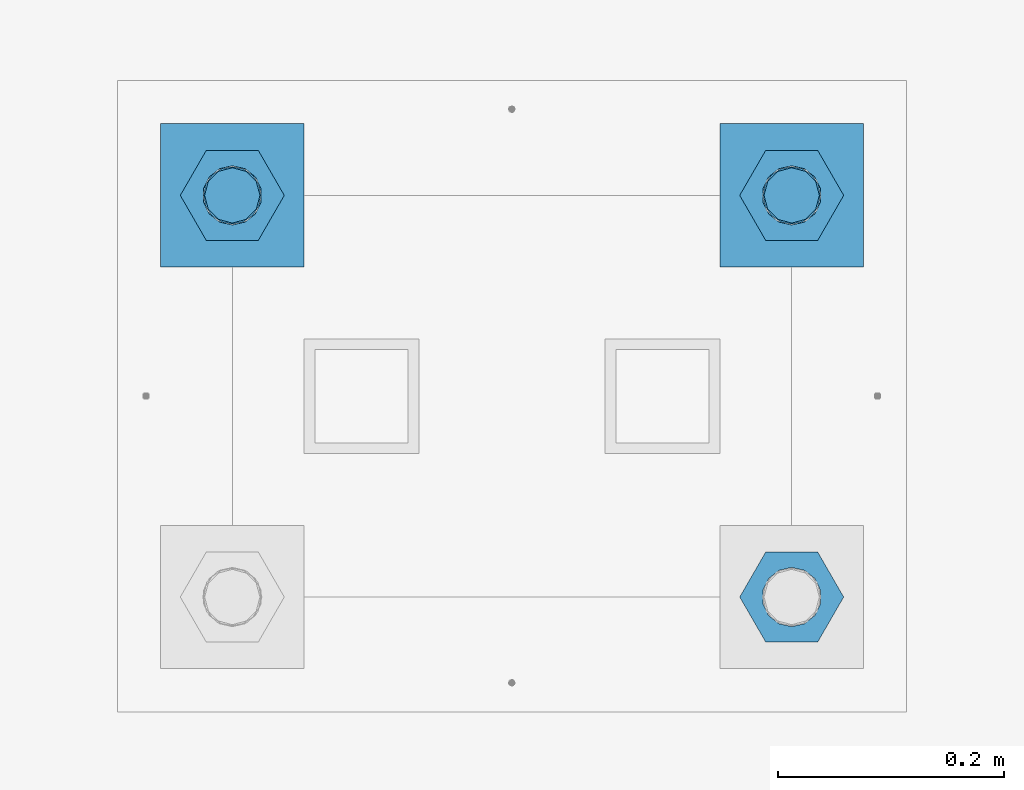
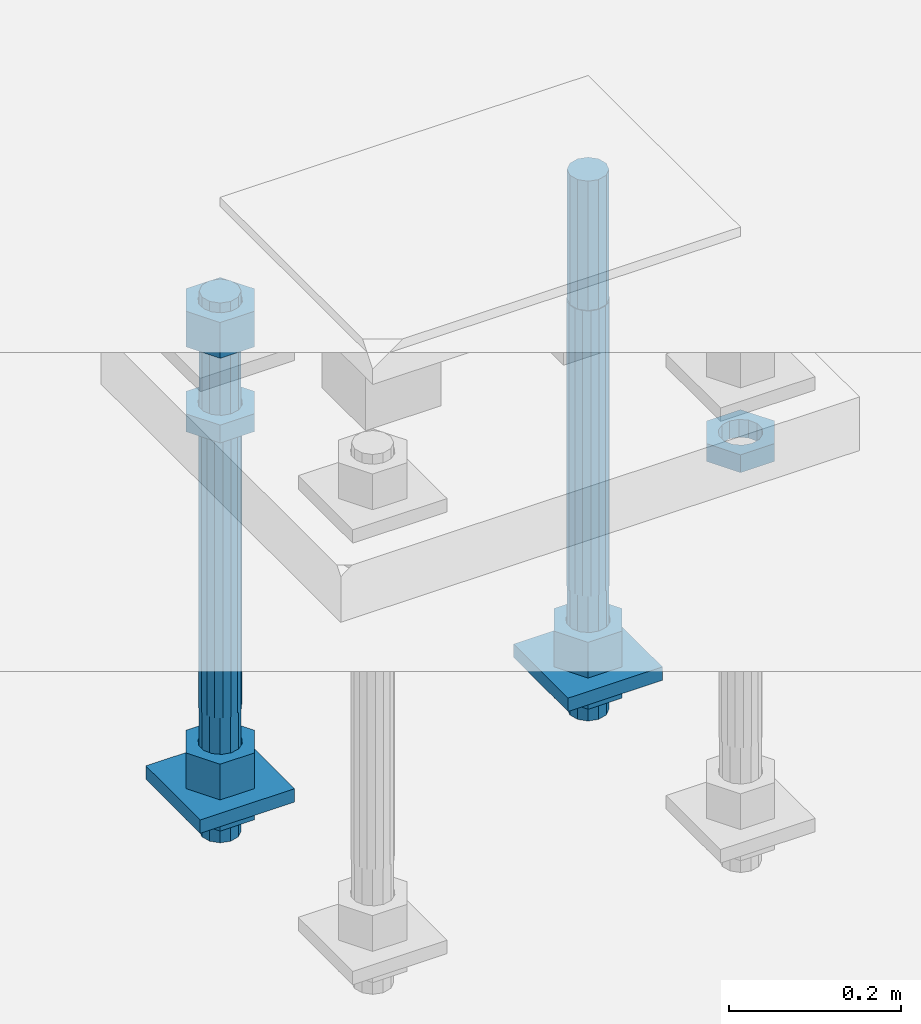
# One storey, part 2691 of 3843: 11 beams, 1 element without a shape of its own.
"""IFC2X3 building model written with IfcOpenShell, lengths in millimetres."""

import ifcopenshell
import ifcopenshell.guid

model = None  # the IFC model being written
_history = None  # IfcOwnerHistory: only IFC2X3 demands one
_inside = {}  # id of a spatial element -> (the spatial element, [elements in it])
_under = {}  # id of a project, library or spatial element -> (it, [spatial elements below it])
_declared = {}  # id of a project -> (the project, [libraries it declares])
_typed = {}  # id of a type object -> (the type object, [elements of that type])
_made_of = {}  # id of a material, layer set ... -> (it, [elements and type objects made of it])


def new_model(schema):
    """Start an empty IFC model of exactly this schema.

    Asked for "IFC4X3", IfcOpenShell would pick the latest addendum, in which some entities
    have other attributes; the version numbers below select the first issue.
    IFC2X3 requires an IfcOwnerHistory on every rooted entity: one is made here for all.
    """
    global model, _history
    if schema == "IFC4X3":
        model = ifcopenshell.file(schema_version=(4, 3, 0, 0))
    else:
        model = ifcopenshell.file(schema=schema)
    _inside.clear()
    _under.clear()
    _declared.clear()
    _typed.clear()
    _made_of.clear()
    _history = None
    if model.schema == "IFC2X3":
        org = make("IfcOrganization", Name="unknown")
        user = make(
            "IfcPersonAndOrganization",
            ThePerson=make("IfcPerson", FamilyName="unknown"),
            TheOrganization=org,
        )
        app = make(
            "IfcApplication",
            ApplicationDeveloper=org,
            Version="unknown",
            ApplicationFullName="unknown",
            ApplicationIdentifier="unknown",
        )
        _history = make(
            "IfcOwnerHistory",
            OwningUser=user,
            OwningApplication=app,
            ChangeAction="ADDED",
            CreationDate=0,
        )
    return model


def make(cls, **values):
    """One entity of the class cls with the attributes given. An attribute that is None is left unset."""
    return model.create_entity(
        cls, **{name: value for name, value in values.items() if value is not None}
    )


def rooted(cls, **values):
    """An entity with a GlobalId (a new one), such as an element, a storey or a relation."""
    return make(cls, GlobalId=ifcopenshell.guid.new(), OwnerHistory=_history, **values)


def si_unit(unit_type, name, prefix=None):
    """IfcSIUnit, for example si_unit("LENGTHUNIT", "METRE", prefix="MILLI")."""
    return make("IfcSIUnit", UnitType=unit_type, Prefix=prefix, Name=name)


def assignment(units):
    """IfcUnitAssignment: the units of a project."""
    return None if units is None else make("IfcUnitAssignment", Units=units)


def point(xyz):
    """IfcCartesianPoint."""
    return None if xyz is None else make("IfcCartesianPoint", Coordinates=xyz)


def direction(xyz):
    """IfcDirection."""
    return None if xyz is None else make("IfcDirection", DirectionRatios=xyz)


def frame(location, z_axis=None, x_axis=None):
    """IfcAxis2Placement3D, a coordinate frame: its origin and axes. An axis left out is left unset."""
    return make(
        "IfcAxis2Placement3D",
        Location=point(location),
        Axis=direction(z_axis),
        RefDirection=direction(x_axis),
    )


def origin_with_axes():
    """The frame at (0, 0, 0) with the z axis (0, 0, 1) and the x axis (1, 0, 0) written out."""
    return frame((0.0, 0.0, 0.0), z_axis=(0.0, 0.0, 1.0), x_axis=(1.0, 0.0, 0.0))


def place(relative_to, where):
    """IfcLocalPlacement: puts the frame where relative to a parent placement (None: the world)."""
    return make(
        "IfcLocalPlacement", PlacementRelTo=relative_to, RelativePlacement=where
    )


def context(
    kind, dimensions, precision=None, world=None, true_north=None, identifier=None
):
    """IfcGeometricRepresentationContext, for example the 3D "Model" context."""
    return make(
        "IfcGeometricRepresentationContext",
        ContextIdentifier=identifier,
        ContextType=kind,
        CoordinateSpaceDimension=dimensions,
        Precision=precision,
        WorldCoordinateSystem=world,
        TrueNorth=true_north,
    )


def subcontext(parent, identifier, kind, view, scale=None):
    """IfcGeometricRepresentationSubContext, for example "Body" below "Model"."""
    return make(
        "IfcGeometricRepresentationSubContext",
        ContextIdentifier=identifier,
        ContextType=kind,
        ParentContext=parent,
        TargetScale=scale,
        TargetView=view,
    )


def project(units=None, contexts=None):
    """IfcProject with its units and contexts."""
    return rooted(
        "IfcProject",
        Name="project",
        RepresentationContexts=contexts,
        UnitsInContext=assignment(units),
    )


def spatial(cls, under=None, at=None, **own):
    """A site, building, storey or space (cls), placed at a placement, below another one or the project."""
    s = rooted(cls, ObjectPlacement=at, **own)
    if under is not None:
        _under.setdefault(under.id(), (under, []))[1].append(s)
    return s


def faces_of(points, faces, orient=None, outer=None):
    """IfcFace entities. A face is a list of loops; a loop is a list of indices into points, from 0.

    orient and outer hold one flag for each loop. By default every Orientation is true, the
    first loop of a face is its IfcFaceOuterBound and the others are IfcFaceBound.
    """
    made = []
    for i, loops in enumerate(faces):
        bounds = []
        for j, loop in enumerate(loops):
            is_outer = j == 0 if outer is None else outer[i][j]
            bounds.append(
                make(
                    "IfcFaceOuterBound" if is_outer else "IfcFaceBound",
                    Bound=make("IfcPolyLoop", Polygon=[points[k] for k in loop]),
                    Orientation=True if orient is None else orient[i][j],
                )
            )
        made.append(make("IfcFace", Bounds=bounds))
    return made


def faceted_brep(points, faces, orient=None, outer=None, voids=None):
    """IfcFacetedBrep: a solid bounded by flat faces; with voids (closed shells), ...WithVoids."""
    shared = [point(p) for p in points]
    hull = make("IfcClosedShell", CfsFaces=faces_of(shared, faces, orient, outer))
    if voids is None:
        return make("IfcFacetedBrep", Outer=hull)
    return make(
        "IfcFacetedBrepWithVoids",
        Outer=hull,
        Voids=[
            make(cls, CfsFaces=faces_of(shared, fs, o, b)) for cls, fs, o, b in voids
        ],
    )


def shape(context_of_items, identifier, shape_type, items):
    """IfcShapeRepresentation: the items that make up one representation, for example the "Body"."""
    return make(
        "IfcShapeRepresentation",
        ContextOfItems=context_of_items,
        RepresentationIdentifier=identifier,
        RepresentationType=shape_type,
        Items=items,
    )


def material(Name=None, Category=None):
    """IfcMaterial."""
    return make("IfcMaterial", Name=Name, Category=Category)


def made_of(thing, what):
    """Note that an element or type object is made of a material, layer set ...; save() writes the relation."""
    if what is not None:
        _made_of.setdefault(what.id(), (what, []))[1].append(thing)
    return thing


def type_object(cls, material=None, **own):
    """A type object (cls), such as IfcWallType, which elements share."""
    return made_of(rooted(cls, **own), material)


def element(
    cls,
    number,
    at=None,
    inside=None,
    cuts=None,
    type_object=None,
    material=None,
    context=None,
    identifier="Body",
    shape_type=None,
    held_by="IfcProductDefinitionShape",
    body=None,
    shapes=None,
    **own,
):
    """One element of the class cls, such as IfcWall. Its Tag is "e" and its number.

    at: its placement. inside: the storey or other place that contains it. cuts: it is an
    opening in that element (IfcRelVoidsElement). A single representation is given by context,
    identifier, shape_type and body (its items); several are given by shapes. held_by: the class
    of the entity that holds the representations. save() writes the other relations.
    """
    e = rooted(cls, Tag="e%d" % number, ObjectPlacement=at, **own)
    if body is not None:
        shapes = [shape(context, identifier, shape_type, body)]
    if shapes is not None:
        e.Representation = make(held_by, Representations=shapes)
    if inside is not None:
        _inside.setdefault(inside.id(), (inside, []))[1].append(e)
    if cuts is not None:
        rooted(
            "IfcRelVoidsElement", RelatingBuildingElement=cuts, RelatedOpeningElement=e
        )
    if type_object is not None:
        _typed.setdefault(type_object.id(), (type_object, []))[1].append(e)
    return made_of(e, material)


def aggregate(whole, parts):
    """IfcRelAggregates: a whole, such as a stair, and the parts it consists of."""
    return rooted("IfcRelAggregates", RelatingObject=whole, RelatedObjects=parts)


def save(model, path):
    """Write the relations noted so far, then the file.

    IfcRelAggregates (storeys below a building ...), IfcRelContainedInSpatialStructure (elements
    in a storey), IfcRelDefinesByType, IfcRelAssociatesMaterial and IfcRelDeclares: one each for
    every whole, place, type object, material and project.
    """
    for whole, parts in _under.values():
        aggregate(whole, parts)
    for where, things in _inside.values():
        rooted(
            "IfcRelContainedInSpatialStructure",
            RelatedElements=things,
            RelatingStructure=where,
        )
    for kind, things in _typed.values():
        rooted("IfcRelDefinesByType", RelatedObjects=things, RelatingType=kind)
    for what, things in _made_of.values():
        rooted("IfcRelAssociatesMaterial", RelatedObjects=things, RelatingMaterial=what)
    for by, libraries in _declared.values():
        rooted("IfcRelDeclares", RelatingContext=by, RelatedDefinitions=libraries)
    model.write(path)


model = new_model("IFC2X3")

# Units and contexts
model_context = context("Model", 3, precision=1e-05, world=origin_with_axes())
body_context = subcontext(model_context, "Body", "Model", "MODEL_VIEW")
ifc_project = project(units=[si_unit("LENGTHUNIT", "METRE", prefix="MILLI"), si_unit("AREAUNIT", "SQUARE_METRE"), si_unit("VOLUMEUNIT", "CUBIC_METRE"), si_unit("MASSUNIT", "GRAM", prefix="KILO"), si_unit("TIMEUNIT", "SECOND"), si_unit("PLANEANGLEUNIT", "RADIAN"), si_unit("SOLIDANGLEUNIT", "STERADIAN"), si_unit("THERMODYNAMICTEMPERATUREUNIT", "DEGREE_CELSIUS"), si_unit("LUMINOUSINTENSITYUNIT", "LUMEN")], contexts=[model_context])

# Site, building, storey
site_placement = place(None, origin_with_axes())
site = spatial("IfcSite", under=ifc_project, at=site_placement, CompositionType="ELEMENT")
building_placement = place(site_placement, origin_with_axes())
building = spatial("IfcBuilding", under=site, at=building_placement, Name="Undefined", CompositionType="ELEMENT")
storey_placement = place(building_placement, origin_with_axes())
storey = spatial("IfcBuildingStorey", under=building, at=storey_placement, Name="Undefined", CompositionType="ELEMENT", Elevation=0.0)

# Assembly, beams
assembly_placement = place(storey_placement, origin_with_axes())
assembly = element("IfcElementAssembly", 1, at=assembly_placement, inside=storey, Name="TEMPLATE", AssemblyPlace="NOTDEFINED", PredefinedType="RIGID_FRAME")
ifc_material_1 = material(Name="STEEL/A572-50")
beam_type_1 = type_object("IfcBeamType", PredefinedType="NOTDEFINED")
beam_1_placement = place(assembly_placement, frame((105403.65, 36258.4999984741, 29244.925), z_axis=(-1.0, 0.0, 0.0), x_axis=(0.0, -1.0, 0.0)))
beam_1 = element("IfcBeam", 2, at=beam_1_placement, type_object=beam_type_1, material=ifc_material_1, Name="WASHER_PLATE", context=body_context, shape_type="Brep", body=[
    faceted_brep([(0.0, 9.52500000000146, -63.5), (0.0, 9.52500000000146, 63.5), (127.0, 9.52500000000146, 63.5), (127.0, 9.52500000000146, -63.5), (0.0, -9.52500000000146, 63.5), (127.0, -9.52500000000146, 63.5), (0.0, -9.52500000000146, -63.5), (127.0, -9.52500000000146, -63.5)], [[[0, 1, 2, 3]], [[1, 4, 5, 2]], [[4, 6, 7, 5]], [[6, 0, 3, 7]], [[5, 7, 3, 2]], [[6, 4, 1, 0]]]),
])
beam_2_placement = place(assembly_placement, frame((104908.35, 36258.4999984741, 29244.925), z_axis=(-1.0, 0.0, 0.0), x_axis=(0.0, -1.0, 0.0)))
beam_2 = element("IfcBeam", 3, at=beam_2_placement, type_object=beam_type_1, material=ifc_material_1, Name="WASHER_PLATE", context=body_context, shape_type="Brep", body=[
    faceted_brep([(0.0, 9.52500000000146, -63.5), (0.0, 9.52500000000146, 63.5), (127.0, 9.52500000000146, 63.5), (127.0, 9.52500000000146, -63.5), (0.0, -9.52500000000146, 63.5), (127.0, -9.52500000000146, 63.5), (0.0, -9.52500000000146, -63.5), (127.0, -9.52500000000146, -63.5)], [[[0, 1, 2, 3]], [[1, 4, 5, 2]], [[4, 6, 7, 5]], [[6, 0, 3, 7]], [[5, 7, 3, 2]], [[6, 4, 1, 0]]]),
])
ifc_material_2 = material(Name="STEEL/A36")
beam_type_2 = type_object("IfcBeamType", Name="2_HALF_NUT", PredefinedType="NOTDEFINED")
beam_3_placement = place(assembly_placement, frame((105403.65, 36194.9999984741, 29235.4), z_axis=(0.0, -1.0, 0.0), x_axis=(0.0, 0.0, -1.0)))
beam_3 = element("IfcBeam", 4, at=beam_3_placement, type_object=beam_type_2, material=ifc_material_2, Name="NUT", ObjectType="2_HALF_NUT", context=body_context, shape_type="Brep", body=[
    faceted_brep([(0.0, -46.0369987487793, 0.0), (0.0, -23.0184993743896, -39.869213104248), (25.4000000000015, -23.0184993743896, -39.869213104248), (25.4000000000015, -46.0369987487793, 0.0), (0.0, 23.0184993743896, -39.869213104248), (25.4000000000015, 23.0184993743896, -39.869213104248), (0.0, 46.0369987487793, 0.0), (25.4000000000015, 46.0369987487793, 0.0), (0.0, 23.0184993743896, 39.869213104248), (25.4000000000015, 23.0184993743896, 39.869213104248), (0.0, -23.0184993743896, 39.869213104248), (25.4000000000015, -23.0184993743896, 39.869213104248), (0.0, 0.0, 26.1940002441406), (0.0, 11.3650617044477, 23.5999013092805), (25.4000000000015, 11.3650617044477, 23.5999013092805), (25.4000000000015, 0.0, 26.1940002441406), (0.0, 20.4791109456419, 16.3316083006721), (25.4000000000015, 20.4791109456419, 16.3316083006721), (0.0, 25.5370200498292, 5.82867859874386), (25.4000000000015, 25.5370200498292, 5.82867859874386), (0.0, 25.5370200498292, -5.82867859874386), (25.4000000000015, 25.5370200498292, -5.82867859874386), (0.0, 20.4791109456419, -16.3316083006721), (25.4000000000015, 20.4791109456419, -16.3316083006721), (0.0, 11.3650617044477, -23.5999013092805), (25.4000000000015, 11.3650617044477, -23.5999013092805), (0.0, 0.0, -26.1940002441406), (25.4000000000015, 0.0, -26.1940002441406), (0.0, -11.3650617044477, -23.5999013092805), (25.4000000000015, -11.3650617044477, -23.5999013092805), (0.0, -20.4791109456419, -16.3316083006721), (25.4000000000015, -20.4791109456419, -16.3316083006721), (0.0, -25.5370200498292, -5.82867859874386), (25.4000000000015, -25.5370200498292, -5.82867859874386), (0.0, -25.5370200498292, 5.82867859874386), (25.4000000000015, -25.5370200498292, 5.82867859874386), (0.0, -20.4791109456419, 16.3316083006721), (25.4000000000015, -20.4791109456419, 16.3316083006721), (0.0, -11.3650617044477, 23.5999013092805), (25.4000000000015, -11.3650617044477, 23.5999013092805)], [[[0, 1, 2, 3]], [[1, 4, 5, 2]], [[4, 6, 7, 5]], [[6, 8, 9, 7]], [[8, 10, 11, 9]], [[10, 0, 3, 11]], [[12, 13, 14, 15]], [[13, 16, 17, 14]], [[16, 18, 19, 17]], [[18, 20, 21, 19]], [[20, 22, 23, 21]], [[22, 24, 25, 23]], [[24, 26, 27, 25]], [[26, 28, 29, 27]], [[28, 30, 31, 29]], [[30, 32, 33, 31]], [[32, 34, 35, 33]], [[34, 36, 37, 35]], [[36, 38, 39, 37]], [[38, 12, 15, 39]], [[5, 7, 9, 11, 3, 2], [17, 19, 21, 23, 25, 27, 29, 31, 33, 35, 37, 39, 15, 14]], [[10, 8, 6, 4, 1, 0], [38, 36, 34, 32, 30, 28, 26, 24, 22, 20, 18, 16, 13, 12]]]),
])
beam_4_placement = place(assembly_placement, frame((104908.35, 36194.9999984741, 29787.85), z_axis=(0.0, -1.0, 0.0), x_axis=(0.0, 0.0, -1.0)))
beam_4 = element("IfcBeam", 5, at=beam_4_placement, type_object=beam_type_2, material=ifc_material_2, Name="NUT", ObjectType="2_HALF_NUT", context=body_context, shape_type="Brep", body=[
    faceted_brep([(0.0, -46.0369987487793, 0.0), (0.0, -23.0184993743896, -39.869213104248), (25.4000000000015, -23.0184993743896, -39.869213104248), (25.4000000000015, -46.0369987487793, 0.0), (0.0, 23.0184993743896, -39.869213104248), (25.4000000000015, 23.0184993743896, -39.869213104248), (0.0, 46.0369987487793, 0.0), (25.4000000000015, 46.0369987487793, 0.0), (0.0, 23.0184993743896, 39.869213104248), (25.4000000000015, 23.0184993743896, 39.869213104248), (0.0, -23.0184993743896, 39.869213104248), (25.4000000000015, -23.0184993743896, 39.869213104248), (0.0, 0.0, 26.1940002441406), (0.0, 11.3650617044477, 23.5999013092805), (25.4000000000015, 11.3650617044477, 23.5999013092805), (25.4000000000015, 0.0, 26.1940002441406), (0.0, 20.4791109456419, 16.3316083006721), (25.4000000000015, 20.4791109456419, 16.3316083006721), (0.0, 25.5370200498292, 5.82867859874386), (25.4000000000015, 25.5370200498292, 5.82867859874386), (0.0, 25.5370200498292, -5.82867859874386), (25.4000000000015, 25.5370200498292, -5.82867859874386), (0.0, 20.4791109456419, -16.3316083006721), (25.4000000000015, 20.4791109456419, -16.3316083006721), (0.0, 11.3650617044477, -23.5999013092805), (25.4000000000015, 11.3650617044477, -23.5999013092805), (0.0, 0.0, -26.1940002441406), (25.4000000000015, 0.0, -26.1940002441406), (0.0, -11.3650617044477, -23.5999013092805), (25.4000000000015, -11.3650617044477, -23.5999013092805), (0.0, -20.4791109456419, -16.3316083006721), (25.4000000000015, -20.4791109456419, -16.3316083006721), (0.0, -25.5370200498292, -5.82867859874386), (25.4000000000015, -25.5370200498292, -5.82867859874386), (0.0, -25.5370200498292, 5.82867859874386), (25.4000000000015, -25.5370200498292, 5.82867859874386), (0.0, -20.4791109456419, 16.3316083006721), (25.4000000000015, -20.4791109456419, 16.3316083006721), (0.0, -11.3650617044477, 23.5999013092805), (25.4000000000015, -11.3650617044477, 23.5999013092805)], [[[0, 1, 2, 3]], [[1, 4, 5, 2]], [[4, 6, 7, 5]], [[6, 8, 9, 7]], [[8, 10, 11, 9]], [[10, 0, 3, 11]], [[12, 13, 14, 15]], [[13, 16, 17, 14]], [[16, 18, 19, 17]], [[18, 20, 21, 19]], [[20, 22, 23, 21]], [[22, 24, 25, 23]], [[24, 26, 27, 25]], [[26, 28, 29, 27]], [[28, 30, 31, 29]], [[30, 32, 33, 31]], [[32, 34, 35, 33]], [[34, 36, 37, 35]], [[36, 38, 39, 37]], [[38, 12, 15, 39]], [[5, 7, 9, 11, 3, 2], [17, 19, 21, 23, 25, 27, 29, 31, 33, 35, 37, 39, 15, 14]], [[10, 8, 6, 4, 1, 0], [38, 36, 34, 32, 30, 28, 26, 24, 22, 20, 18, 16, 13, 12]]]),
])
beam_5_placement = place(assembly_placement, frame((104908.35, 36194.9999984741, 29235.4), z_axis=(0.0, -1.0, 0.0), x_axis=(0.0, 0.0, -1.0)))
beam_5 = element("IfcBeam", 6, at=beam_5_placement, type_object=beam_type_2, material=ifc_material_2, Name="NUT", ObjectType="2_HALF_NUT", context=body_context, shape_type="Brep", body=[
    faceted_brep([(0.0, -46.0369987487793, 0.0), (0.0, -23.0184993743896, -39.869213104248), (25.4000000000015, -23.0184993743896, -39.869213104248), (25.4000000000015, -46.0369987487793, 0.0), (0.0, 23.0184993743896, -39.869213104248), (25.4000000000015, 23.0184993743896, -39.869213104248), (0.0, 46.0369987487793, 0.0), (25.4000000000015, 46.0369987487793, 0.0), (0.0, 23.0184993743896, 39.869213104248), (25.4000000000015, 23.0184993743896, 39.869213104248), (0.0, -23.0184993743896, 39.869213104248), (25.4000000000015, -23.0184993743896, 39.869213104248), (0.0, 0.0, 26.1940002441406), (0.0, 11.3650617044477, 23.5999013092805), (25.4000000000015, 11.3650617044477, 23.5999013092805), (25.4000000000015, 0.0, 26.1940002441406), (0.0, 20.4791109456419, 16.3316083006721), (25.4000000000015, 20.4791109456419, 16.3316083006721), (0.0, 25.5370200498292, 5.82867859874386), (25.4000000000015, 25.5370200498292, 5.82867859874386), (0.0, 25.5370200498292, -5.82867859874386), (25.4000000000015, 25.5370200498292, -5.82867859874386), (0.0, 20.4791109456419, -16.3316083006721), (25.4000000000015, 20.4791109456419, -16.3316083006721), (0.0, 11.3650617044477, -23.5999013092805), (25.4000000000015, 11.3650617044477, -23.5999013092805), (0.0, 0.0, -26.1940002441406), (25.4000000000015, 0.0, -26.1940002441406), (0.0, -11.3650617044477, -23.5999013092805), (25.4000000000015, -11.3650617044477, -23.5999013092805), (0.0, -20.4791109456419, -16.3316083006721), (25.4000000000015, -20.4791109456419, -16.3316083006721), (0.0, -25.5370200498292, -5.82867859874386), (25.4000000000015, -25.5370200498292, -5.82867859874386), (0.0, -25.5370200498292, 5.82867859874386), (25.4000000000015, -25.5370200498292, 5.82867859874386), (0.0, -20.4791109456419, 16.3316083006721), (25.4000000000015, -20.4791109456419, 16.3316083006721), (0.0, -11.3650617044477, 23.5999013092805), (25.4000000000015, -11.3650617044477, 23.5999013092805)], [[[0, 1, 2, 3]], [[1, 4, 5, 2]], [[4, 6, 7, 5]], [[6, 8, 9, 7]], [[8, 10, 11, 9]], [[10, 0, 3, 11]], [[12, 13, 14, 15]], [[13, 16, 17, 14]], [[16, 18, 19, 17]], [[18, 20, 21, 19]], [[20, 22, 23, 21]], [[22, 24, 25, 23]], [[24, 26, 27, 25]], [[26, 28, 29, 27]], [[28, 30, 31, 29]], [[30, 32, 33, 31]], [[32, 34, 35, 33]], [[34, 36, 37, 35]], [[36, 38, 39, 37]], [[38, 12, 15, 39]], [[5, 7, 9, 11, 3, 2], [17, 19, 21, 23, 25, 27, 29, 31, 33, 35, 37, 39, 15, 14]], [[10, 8, 6, 4, 1, 0], [38, 36, 34, 32, 30, 28, 26, 24, 22, 20, 18, 16, 13, 12]]]),
])
beam_6_placement = place(assembly_placement, frame((105403.65, 35839.3999984741, 29787.85), z_axis=(0.0, -1.0, 0.0), x_axis=(0.0, 0.0, -1.0)))
beam_6 = element("IfcBeam", 7, at=beam_6_placement, type_object=beam_type_2, material=ifc_material_2, Name="NUT", ObjectType="2_HALF_NUT", context=body_context, shape_type="Brep", body=[
    faceted_brep([(0.0, -46.0369987487793, 0.0), (0.0, -23.0184993743896, -39.869213104248), (25.4000000000015, -23.0184993743896, -39.869213104248), (25.4000000000015, -46.0369987487793, 0.0), (0.0, 23.0184993743896, -39.869213104248), (25.4000000000015, 23.0184993743896, -39.869213104248), (0.0, 46.0369987487793, 0.0), (25.4000000000015, 46.0369987487793, 0.0), (0.0, 23.0184993743896, 39.869213104248), (25.4000000000015, 23.0184993743896, 39.869213104248), (0.0, -23.0184993743896, 39.869213104248), (25.4000000000015, -23.0184993743896, 39.869213104248), (0.0, 0.0, 26.1940002441406), (0.0, 11.3650617044477, 23.5999013092805), (25.4000000000015, 11.3650617044477, 23.5999013092805), (25.4000000000015, 0.0, 26.1940002441406), (0.0, 20.4791109456419, 16.3316083006721), (25.4000000000015, 20.4791109456419, 16.3316083006721), (0.0, 25.5370200498292, 5.82867859874386), (25.4000000000015, 25.5370200498292, 5.82867859874386), (0.0, 25.5370200498292, -5.82867859874386), (25.4000000000015, 25.5370200498292, -5.82867859874386), (0.0, 20.4791109456419, -16.3316083006721), (25.4000000000015, 20.4791109456419, -16.3316083006721), (0.0, 11.3650617044477, -23.5999013092805), (25.4000000000015, 11.3650617044477, -23.5999013092805), (0.0, 0.0, -26.1940002441406), (25.4000000000015, 0.0, -26.1940002441406), (0.0, -11.3650617044477, -23.5999013092805), (25.4000000000015, -11.3650617044477, -23.5999013092805), (0.0, -20.4791109456419, -16.3316083006721), (25.4000000000015, -20.4791109456419, -16.3316083006721), (0.0, -25.5370200498292, -5.82867859874386), (25.4000000000015, -25.5370200498292, -5.82867859874386), (0.0, -25.5370200498292, 5.82867859874386), (25.4000000000015, -25.5370200498292, 5.82867859874386), (0.0, -20.4791109456419, 16.3316083006721), (25.4000000000015, -20.4791109456419, 16.3316083006721), (0.0, -11.3650617044477, 23.5999013092805), (25.4000000000015, -11.3650617044477, 23.5999013092805)], [[[0, 1, 2, 3]], [[1, 4, 5, 2]], [[4, 6, 7, 5]], [[6, 8, 9, 7]], [[8, 10, 11, 9]], [[10, 0, 3, 11]], [[12, 13, 14, 15]], [[13, 16, 17, 14]], [[16, 18, 19, 17]], [[18, 20, 21, 19]], [[20, 22, 23, 21]], [[22, 24, 25, 23]], [[24, 26, 27, 25]], [[26, 28, 29, 27]], [[28, 30, 31, 29]], [[30, 32, 33, 31]], [[32, 34, 35, 33]], [[34, 36, 37, 35]], [[36, 38, 39, 37]], [[38, 12, 15, 39]], [[5, 7, 9, 11, 3, 2], [17, 19, 21, 23, 25, 27, 29, 31, 33, 35, 37, 39, 15, 14]], [[10, 8, 6, 4, 1, 0], [38, 36, 34, 32, 30, 28, 26, 24, 22, 20, 18, 16, 13, 12]]]),
])
beam_type_3 = type_object("IfcBeamType", Name="2_HEAVY_HEX_NUT", PredefinedType="NOTDEFINED")
beam_7_placement = place(assembly_placement, frame((105403.65, 36194.9999984741, 29305.25), z_axis=(0.0, -1.0, 0.0), x_axis=(0.0, 0.0, -1.0)))
beam_7 = element("IfcBeam", 8, at=beam_7_placement, type_object=beam_type_3, material=ifc_material_2, Name="NUT", ObjectType="2_HEAVY_HEX_NUT", context=body_context, shape_type="Brep", body=[
    faceted_brep([(0.0, -46.0369987487793, 0.0), (0.0, -23.0184993743896, -39.869213104248), (50.7999999999993, -23.0184993743896, -39.869213104248), (50.7999999999993, -46.0369987487793, 0.0), (0.0, 23.0184993743896, -39.869213104248), (50.7999999999993, 23.0184993743896, -39.869213104248), (0.0, 46.0369987487793, 0.0), (50.7999999999993, 46.0369987487793, 0.0), (0.0, 23.0184993743896, 39.869213104248), (50.7999999999993, 23.0184993743896, 39.869213104248), (0.0, -23.0184993743896, 39.869213104248), (50.7999999999993, -23.0184993743896, 39.869213104248), (0.0, 0.0, 26.1940002441406), (0.0, 11.3650617044477, 23.5999013092805), (50.7999999999993, 11.3650617044477, 23.5999013092805), (50.7999999999993, 0.0, 26.1940002441406), (0.0, 20.4791109456419, 16.3316083006721), (50.7999999999993, 20.4791109456419, 16.3316083006721), (0.0, 25.5370200498292, 5.82867859874386), (50.7999999999993, 25.5370200498292, 5.82867859874386), (0.0, 25.5370200498292, -5.82867859874386), (50.7999999999993, 25.5370200498292, -5.82867859874386), (0.0, 20.4791109456419, -16.3316083006721), (50.7999999999993, 20.4791109456419, -16.3316083006721), (0.0, 11.3650617044477, -23.5999013092805), (50.7999999999993, 11.3650617044477, -23.5999013092805), (0.0, 0.0, -26.1940002441406), (50.7999999999993, 0.0, -26.1940002441406), (0.0, -11.3650617044477, -23.5999013092805), (50.7999999999993, -11.3650617044477, -23.5999013092805), (0.0, -20.4791109456419, -16.3316083006721), (50.7999999999993, -20.4791109456419, -16.3316083006721), (0.0, -25.5370200498292, -5.82867859874386), (50.7999999999993, -25.5370200498292, -5.82867859874386), (0.0, -25.5370200498292, 5.82867859874386), (50.7999999999993, -25.5370200498292, 5.82867859874386), (0.0, -20.4791109456419, 16.3316083006721), (50.7999999999993, -20.4791109456419, 16.3316083006721), (0.0, -11.3650617044477, 23.5999013092805), (50.7999999999993, -11.3650617044477, 23.5999013092805)], [[[0, 1, 2, 3]], [[1, 4, 5, 2]], [[4, 6, 7, 5]], [[6, 8, 9, 7]], [[8, 10, 11, 9]], [[10, 0, 3, 11]], [[12, 13, 14, 15]], [[13, 16, 17, 14]], [[16, 18, 19, 17]], [[18, 20, 21, 19]], [[20, 22, 23, 21]], [[22, 24, 25, 23]], [[24, 26, 27, 25]], [[26, 28, 29, 27]], [[28, 30, 31, 29]], [[30, 32, 33, 31]], [[32, 34, 35, 33]], [[34, 36, 37, 35]], [[36, 38, 39, 37]], [[38, 12, 15, 39]], [[5, 7, 9, 11, 3, 2], [17, 19, 21, 23, 25, 27, 29, 31, 33, 35, 37, 39, 15, 14]], [[10, 8, 6, 4, 1, 0], [38, 36, 34, 32, 30, 28, 26, 24, 22, 20, 18, 16, 13, 12]]]),
])
beam_8_placement = place(assembly_placement, frame((104908.35, 36194.9999984741, 29933.9), z_axis=(0.0, -1.0, 0.0), x_axis=(0.0, 0.0, -1.0)))
beam_8 = element("IfcBeam", 9, at=beam_8_placement, type_object=beam_type_3, material=ifc_material_2, Name="NUT", ObjectType="2_HEAVY_HEX_NUT", context=body_context, shape_type="Brep", body=[
    faceted_brep([(0.0, -46.0369987487793, 0.0), (0.0, -23.0184993743896, -39.869213104248), (50.7999999999993, -23.0184993743896, -39.869213104248), (50.7999999999993, -46.0369987487793, 0.0), (0.0, 23.0184993743896, -39.869213104248), (50.7999999999993, 23.0184993743896, -39.869213104248), (0.0, 46.0369987487793, 0.0), (50.7999999999993, 46.0369987487793, 0.0), (0.0, 23.0184993743896, 39.869213104248), (50.7999999999993, 23.0184993743896, 39.869213104248), (0.0, -23.0184993743896, 39.869213104248), (50.7999999999993, -23.0184993743896, 39.869213104248), (0.0, 0.0, 26.1940002441406), (0.0, 11.3650617044477, 23.5999013092805), (50.7999999999993, 11.3650617044477, 23.5999013092805), (50.7999999999993, 0.0, 26.1940002441406), (0.0, 20.4791109456419, 16.3316083006721), (50.7999999999993, 20.4791109456419, 16.3316083006721), (0.0, 25.5370200498292, 5.82867859874386), (50.7999999999993, 25.5370200498292, 5.82867859874386), (0.0, 25.5370200498292, -5.82867859874386), (50.7999999999993, 25.5370200498292, -5.82867859874386), (0.0, 20.4791109456419, -16.3316083006721), (50.7999999999993, 20.4791109456419, -16.3316083006721), (0.0, 11.3650617044477, -23.5999013092805), (50.7999999999993, 11.3650617044477, -23.5999013092805), (0.0, 0.0, -26.1940002441406), (50.7999999999993, 0.0, -26.1940002441406), (0.0, -11.3650617044477, -23.5999013092805), (50.7999999999993, -11.3650617044477, -23.5999013092805), (0.0, -20.4791109456419, -16.3316083006721), (50.7999999999993, -20.4791109456419, -16.3316083006721), (0.0, -25.5370200498292, -5.82867859874386), (50.7999999999993, -25.5370200498292, -5.82867859874386), (0.0, -25.5370200498292, 5.82867859874386), (50.7999999999993, -25.5370200498292, 5.82867859874386), (0.0, -20.4791109456419, 16.3316083006721), (50.7999999999993, -20.4791109456419, 16.3316083006721), (0.0, -11.3650617044477, 23.5999013092805), (50.7999999999993, -11.3650617044477, 23.5999013092805)], [[[0, 1, 2, 3]], [[1, 4, 5, 2]], [[4, 6, 7, 5]], [[6, 8, 9, 7]], [[8, 10, 11, 9]], [[10, 0, 3, 11]], [[12, 13, 14, 15]], [[13, 16, 17, 14]], [[16, 18, 19, 17]], [[18, 20, 21, 19]], [[20, 22, 23, 21]], [[22, 24, 25, 23]], [[24, 26, 27, 25]], [[26, 28, 29, 27]], [[28, 30, 31, 29]], [[30, 32, 33, 31]], [[32, 34, 35, 33]], [[34, 36, 37, 35]], [[36, 38, 39, 37]], [[38, 12, 15, 39]], [[5, 7, 9, 11, 3, 2], [17, 19, 21, 23, 25, 27, 29, 31, 33, 35, 37, 39, 15, 14]], [[10, 8, 6, 4, 1, 0], [38, 36, 34, 32, 30, 28, 26, 24, 22, 20, 18, 16, 13, 12]]]),
])
beam_9_placement = place(assembly_placement, frame((104908.35, 36194.9999984741, 29305.25), z_axis=(0.0, -1.0, 0.0), x_axis=(0.0, 0.0, -1.0)))
beam_9 = element("IfcBeam", 10, at=beam_9_placement, type_object=beam_type_3, material=ifc_material_2, Name="NUT", ObjectType="2_HEAVY_HEX_NUT", context=body_context, shape_type="Brep", body=[
    faceted_brep([(0.0, -46.0369987487793, 0.0), (0.0, -23.0184993743896, -39.869213104248), (50.7999999999993, -23.0184993743896, -39.869213104248), (50.7999999999993, -46.0369987487793, 0.0), (0.0, 23.0184993743896, -39.869213104248), (50.7999999999993, 23.0184993743896, -39.869213104248), (0.0, 46.0369987487793, 0.0), (50.7999999999993, 46.0369987487793, 0.0), (0.0, 23.0184993743896, 39.869213104248), (50.7999999999993, 23.0184993743896, 39.869213104248), (0.0, -23.0184993743896, 39.869213104248), (50.7999999999993, -23.0184993743896, 39.869213104248), (0.0, 0.0, 26.1940002441406), (0.0, 11.3650617044477, 23.5999013092805), (50.7999999999993, 11.3650617044477, 23.5999013092805), (50.7999999999993, 0.0, 26.1940002441406), (0.0, 20.4791109456419, 16.3316083006721), (50.7999999999993, 20.4791109456419, 16.3316083006721), (0.0, 25.5370200498292, 5.82867859874386), (50.7999999999993, 25.5370200498292, 5.82867859874386), (0.0, 25.5370200498292, -5.82867859874386), (50.7999999999993, 25.5370200498292, -5.82867859874386), (0.0, 20.4791109456419, -16.3316083006721), (50.7999999999993, 20.4791109456419, -16.3316083006721), (0.0, 11.3650617044477, -23.5999013092805), (50.7999999999993, 11.3650617044477, -23.5999013092805), (0.0, 0.0, -26.1940002441406), (50.7999999999993, 0.0, -26.1940002441406), (0.0, -11.3650617044477, -23.5999013092805), (50.7999999999993, -11.3650617044477, -23.5999013092805), (0.0, -20.4791109456419, -16.3316083006721), (50.7999999999993, -20.4791109456419, -16.3316083006721), (0.0, -25.5370200498292, -5.82867859874386), (50.7999999999993, -25.5370200498292, -5.82867859874386), (0.0, -25.5370200498292, 5.82867859874386), (50.7999999999993, -25.5370200498292, 5.82867859874386), (0.0, -20.4791109456419, 16.3316083006721), (50.7999999999993, -20.4791109456419, 16.3316083006721), (0.0, -11.3650617044477, 23.5999013092805), (50.7999999999993, -11.3650617044477, 23.5999013092805)], [[[0, 1, 2, 3]], [[1, 4, 5, 2]], [[4, 6, 7, 5]], [[6, 8, 9, 7]], [[8, 10, 11, 9]], [[10, 0, 3, 11]], [[12, 13, 14, 15]], [[13, 16, 17, 14]], [[16, 18, 19, 17]], [[18, 20, 21, 19]], [[20, 22, 23, 21]], [[22, 24, 25, 23]], [[24, 26, 27, 25]], [[26, 28, 29, 27]], [[28, 30, 31, 29]], [[30, 32, 33, 31]], [[32, 34, 35, 33]], [[34, 36, 37, 35]], [[36, 38, 39, 37]], [[38, 12, 15, 39]], [[5, 7, 9, 11, 3, 2], [17, 19, 21, 23, 25, 27, 29, 31, 33, 35, 37, 39, 15, 14]], [[10, 8, 6, 4, 1, 0], [38, 36, 34, 32, 30, 28, 26, 24, 22, 20, 18, 16, 13, 12]]]),
])
ifc_material_3 = material()
beam_type_4 = type_object("IfcBeamType", PredefinedType="NOTDEFINED")
beam_10_placement = place(assembly_placement, frame((105403.65, 36194.9999984741, 29762.45), z_axis=(0.0, -1.0, 0.0), x_axis=(0.0, 0.0, -1.0)))
beam_10 = element("IfcBeam", 11, at=beam_10_placement, type_object=beam_type_4, material=ifc_material_3, Name="ANCHOR_ROD", context=body_context, shape_type="Brep", body=[
    faceted_brep([(-184.150000000001, -21.217622392709, 12.25), (-184.150000000001, -12.2499999999854, 21.2176223927163), (-184.150000000001, 1.45519152283669e-11, 24.5), (-184.150000000001, 12.2500000000146, 21.2176223927163), (-184.150000000001, 21.2176223927381, 12.25), (-184.150000000001, 24.5000000000146, 0.0), (-184.150000000001, 21.2176223927381, -12.25), (-184.150000000001, 12.2500000000146, -21.2176223927163), (-184.150000000001, 1.45519152283669e-11, -24.5), (-184.150000000001, -12.2499999999854, -21.2176223927163), (-184.150000000001, -21.217622392709, -12.25), (-184.150000000001, -24.4999999999854, 0.0), (0.0, 24.5000000000146, 0.0), (0.0, 21.2176223927381, -12.25), (0.0, 12.2500000000146, -21.2176223927163), (0.0, 1.45519152283669e-11, -24.5), (0.0, -12.2499999999854, -21.2176223927163), (0.0, -21.217622392709, -12.25), (0.0, -24.4999999999854, 0.0), (0.0, -21.217622392709, 12.25), (0.0, -12.2499999999854, 21.2176223927163), (0.0, 1.45519152283669e-11, 24.5), (0.0, 12.2500000000146, 21.2176223927163), (0.0, 21.2176223927381, 12.25), (0.0, -23.4665401257807, 9.72015918207035), (0.0, -17.9605122421344, 17.9605122421417), (0.0, -9.72015918207762, 23.466540125788), (0.0, 0.0, 25.4000000000015), (0.0, 9.72015918207762, 23.466540125788), (0.0, 17.9605122421344, 17.9605122421417), (0.0, 23.4665401257807, 9.72015918207035), (0.0, 25.3999996185303, 0.0), (0.0, 23.4665401257807, -9.72015918207035), (0.0, 17.9605122421344, -17.9605122421417), (0.0, 9.72015918207762, -23.466540125788), (0.0, 0.0, -25.4000000000015), (0.0, -9.72015918207762, -23.466540125788), (0.0, -17.9605122421344, -17.9605122421417), (0.0, -23.4665401257807, -9.72015918207035), (0.0, -25.3999996185303, 0.0), (406.399999999998, -25.3999999999942, 0.0), (406.399999999998, -23.4665401257807, 9.72015918207035), (406.399999999998, -17.9605122421344, 17.9605122421417), (406.399999999998, -9.72015918207762, 23.466540125788), (406.399999999998, 0.0, 25.4000000000015), (406.399999999998, 9.72015918207762, 23.466540125788), (406.399999999998, 17.9605122421344, 17.9605122421417), (406.399999999998, 23.4665401257807, 9.72015918207035), (406.399999999998, 25.3999999999942, 0.0), (406.399999999998, 23.4665401257807, -9.72015918207035), (406.399999999998, 17.9605122421344, -17.9605122421417), (406.399999999998, 9.72015918207762, -23.466540125788), (406.399999999998, 0.0, -25.4000000000015), (406.399999999998, -9.72015918207762, -23.466540125788), (406.399999999998, -17.9605122421344, -17.9605122421417), (406.399999999998, -23.4665401257807, -9.72015918207035), (406.399999999998, -12.2499999999854, 21.2176223927163), (406.399999999998, 1.45519152283669e-11, 24.5), (406.399999999998, 12.2500000000146, 21.2176223927163), (406.399999999998, 21.2176223927381, 12.25), (406.399999999998, 24.5000000000146, 0.0), (406.399999999998, 21.2176223927381, -12.25), (406.399999999998, 12.2500000000146, -21.2176223927163), (406.399999999998, 1.45519152283669e-11, -24.5), (406.399999999998, -12.2499999999854, -21.2176223927163), (406.399999999998, -21.217622392709, -12.25), (406.399999999998, -24.4999999999854, 0.0), (406.399999999998, -21.217622392709, 12.25), (584.200000000001, -12.2499999999854, -21.2176223927163), (584.200000000001, 1.45519152283669e-11, -24.5), (584.200000000001, 12.2500000000146, -21.2176223927163), (584.200000000001, 21.2176223927381, -12.25), (584.200000000001, 24.5000000000146, 0.0), (584.200000000001, 21.2176223927381, 12.25), (584.200000000001, 12.2500000000146, 21.2176223927163), (584.200000000001, 1.45519152283669e-11, 24.5), (584.200000000001, -12.2499999999854, 21.2176223927163), (584.200000000001, -21.217622392709, 12.25), (584.200000000001, -24.4999999999854, 0.0), (584.200000000001, -21.217622392709, -12.25)], [[[0, 1, 2, 3, 4, 5, 6, 7, 8, 9, 10, 11]], [[6, 5, 12, 13]], [[7, 6, 13, 14]], [[8, 7, 14, 15]], [[9, 8, 15, 16]], [[10, 9, 16, 17]], [[11, 10, 17, 18]], [[0, 11, 18, 19]], [[1, 0, 19, 20]], [[2, 1, 20, 21]], [[3, 2, 21, 22]], [[4, 3, 22, 23]], [[5, 4, 23, 12]], [[24, 25, 26, 27, 28, 29, 30, 31, 32, 33, 34, 35, 36, 37, 38, 39], [22, 21, 20, 19, 18, 17, 16, 15, 14, 13, 12, 23]], [[24, 39, 40, 41]], [[25, 24, 41, 42]], [[26, 25, 42, 43]], [[27, 26, 43, 44]], [[28, 27, 44, 45]], [[29, 28, 45, 46]], [[30, 29, 46, 47]], [[31, 30, 47, 48]], [[32, 31, 48, 49]], [[33, 32, 49, 50]], [[34, 33, 50, 51]], [[35, 34, 51, 52]], [[36, 35, 52, 53]], [[37, 36, 53, 54]], [[38, 37, 54, 55]], [[39, 38, 55, 40]], [[54, 53, 52, 51, 50, 49, 48, 47, 46, 45, 44, 43, 42, 41, 40, 55], [56, 57, 58, 59, 60, 61, 62, 63, 64, 65, 66, 67]], [[68, 69, 70, 71, 72, 73, 74, 75, 76, 77, 78, 79]], [[76, 75, 57, 56]], [[77, 76, 56, 67]], [[78, 77, 67, 66]], [[79, 78, 66, 65]], [[68, 79, 65, 64]], [[69, 68, 64, 63]], [[70, 69, 63, 62]], [[71, 70, 62, 61]], [[72, 71, 61, 60]], [[73, 72, 60, 59]], [[74, 73, 59, 58]], [[75, 74, 58, 57]]]),
])
beam_11_placement = place(assembly_placement, frame((104908.35, 36194.9999984741, 29762.45), z_axis=(0.0, -1.0, 0.0), x_axis=(0.0, 0.0, -1.0)))
beam_11 = element("IfcBeam", 12, at=beam_11_placement, type_object=beam_type_4, material=ifc_material_3, Name="ANCHOR_ROD", context=body_context, shape_type="Brep", body=[
    faceted_brep([(-184.150000000001, -21.217622392709, 12.25), (-184.150000000001, -12.2499999999854, 21.2176223927163), (-184.150000000001, 1.45519152283669e-11, 24.5), (-184.150000000001, 12.2500000000146, 21.2176223927163), (-184.150000000001, 21.2176223927381, 12.25), (-184.150000000001, 24.5000000000146, 0.0), (-184.150000000001, 21.2176223927381, -12.25), (-184.150000000001, 12.2500000000146, -21.2176223927163), (-184.150000000001, 1.45519152283669e-11, -24.5), (-184.150000000001, -12.2499999999854, -21.2176223927163), (-184.150000000001, -21.217622392709, -12.25), (-184.150000000001, -24.4999999999854, 0.0), (0.0, 24.5000000000146, 0.0), (0.0, 21.2176223927381, -12.25), (0.0, 12.2500000000146, -21.2176223927163), (0.0, 1.45519152283669e-11, -24.5), (0.0, -12.2499999999854, -21.2176223927163), (0.0, -21.217622392709, -12.25), (0.0, -24.4999999999854, 0.0), (0.0, -21.217622392709, 12.25), (0.0, -12.2499999999854, 21.2176223927163), (0.0, 1.45519152283669e-11, 24.5), (0.0, 12.2500000000146, 21.2176223927163), (0.0, 21.2176223927381, 12.25), (0.0, -23.4665401257807, 9.72015918207035), (0.0, -17.9605122421344, 17.9605122421417), (0.0, -9.72015918207762, 23.466540125788), (0.0, 0.0, 25.4000000000015), (0.0, 9.72015918207762, 23.466540125788), (0.0, 17.9605122421344, 17.9605122421417), (0.0, 23.4665401257807, 9.72015918207035), (0.0, 25.3999996185303, 0.0), (0.0, 23.4665401257807, -9.72015918207035), (0.0, 17.9605122421344, -17.9605122421417), (0.0, 9.72015918207762, -23.466540125788), (0.0, 0.0, -25.4000000000015), (0.0, -9.72015918207762, -23.466540125788), (0.0, -17.9605122421344, -17.9605122421417), (0.0, -23.4665401257807, -9.72015918207035), (0.0, -25.3999996185303, 0.0), (406.399999999998, -25.3999999999942, 0.0), (406.399999999998, -23.4665401257807, 9.72015918207035), (406.399999999998, -17.9605122421344, 17.9605122421417), (406.399999999998, -9.72015918207762, 23.466540125788), (406.399999999998, 0.0, 25.4000000000015), (406.399999999998, 9.72015918207762, 23.466540125788), (406.399999999998, 17.9605122421344, 17.9605122421417), (406.399999999998, 23.4665401257807, 9.72015918207035), (406.399999999998, 25.3999999999942, 0.0), (406.399999999998, 23.4665401257807, -9.72015918207035), (406.399999999998, 17.9605122421344, -17.9605122421417), (406.399999999998, 9.72015918207762, -23.466540125788), (406.399999999998, 0.0, -25.4000000000015), (406.399999999998, -9.72015918207762, -23.466540125788), (406.399999999998, -17.9605122421344, -17.9605122421417), (406.399999999998, -23.4665401257807, -9.72015918207035), (406.399999999998, -12.2499999999854, 21.2176223927163), (406.399999999998, 1.45519152283669e-11, 24.5), (406.399999999998, 12.2500000000146, 21.2176223927163), (406.399999999998, 21.2176223927381, 12.25), (406.399999999998, 24.5000000000146, 0.0), (406.399999999998, 21.2176223927381, -12.25), (406.399999999998, 12.2500000000146, -21.2176223927163), (406.399999999998, 1.45519152283669e-11, -24.5), (406.399999999998, -12.2499999999854, -21.2176223927163), (406.399999999998, -21.217622392709, -12.25), (406.399999999998, -24.4999999999854, 0.0), (406.399999999998, -21.217622392709, 12.25), (584.200000000001, -12.2499999999854, -21.2176223927163), (584.200000000001, 1.45519152283669e-11, -24.5), (584.200000000001, 12.2500000000146, -21.2176223927163), (584.200000000001, 21.2176223927381, -12.25), (584.200000000001, 24.5000000000146, 0.0), (584.200000000001, 21.2176223927381, 12.25), (584.200000000001, 12.2500000000146, 21.2176223927163), (584.200000000001, 1.45519152283669e-11, 24.5), (584.200000000001, -12.2499999999854, 21.2176223927163), (584.200000000001, -21.217622392709, 12.25), (584.200000000001, -24.4999999999854, 0.0), (584.200000000001, -21.217622392709, -12.25)], [[[0, 1, 2, 3, 4, 5, 6, 7, 8, 9, 10, 11]], [[6, 5, 12, 13]], [[7, 6, 13, 14]], [[8, 7, 14, 15]], [[9, 8, 15, 16]], [[10, 9, 16, 17]], [[11, 10, 17, 18]], [[0, 11, 18, 19]], [[1, 0, 19, 20]], [[2, 1, 20, 21]], [[3, 2, 21, 22]], [[4, 3, 22, 23]], [[5, 4, 23, 12]], [[24, 25, 26, 27, 28, 29, 30, 31, 32, 33, 34, 35, 36, 37, 38, 39], [22, 21, 20, 19, 18, 17, 16, 15, 14, 13, 12, 23]], [[24, 39, 40, 41]], [[25, 24, 41, 42]], [[26, 25, 42, 43]], [[27, 26, 43, 44]], [[28, 27, 44, 45]], [[29, 28, 45, 46]], [[30, 29, 46, 47]], [[31, 30, 47, 48]], [[32, 31, 48, 49]], [[33, 32, 49, 50]], [[34, 33, 50, 51]], [[35, 34, 51, 52]], [[36, 35, 52, 53]], [[37, 36, 53, 54]], [[38, 37, 54, 55]], [[39, 38, 55, 40]], [[54, 53, 52, 51, 50, 49, 48, 47, 46, 45, 44, 43, 42, 41, 40, 55], [56, 57, 58, 59, 60, 61, 62, 63, 64, 65, 66, 67]], [[68, 69, 70, 71, 72, 73, 74, 75, 76, 77, 78, 79]], [[76, 75, 57, 56]], [[77, 76, 56, 67]], [[78, 77, 67, 66]], [[79, 78, 66, 65]], [[68, 79, 65, 64]], [[69, 68, 64, 63]], [[70, 69, 63, 62]], [[71, 70, 62, 61]], [[72, 71, 61, 60]], [[73, 72, 60, 59]], [[74, 73, 59, 58]], [[75, 74, 58, 57]]]),
])
aggregate(assembly, [beam_7, beam_3, beam_1, beam_10, beam_4, beam_8, beam_9, beam_5, beam_2, beam_11, beam_6])

save(model, "model.ifc")
